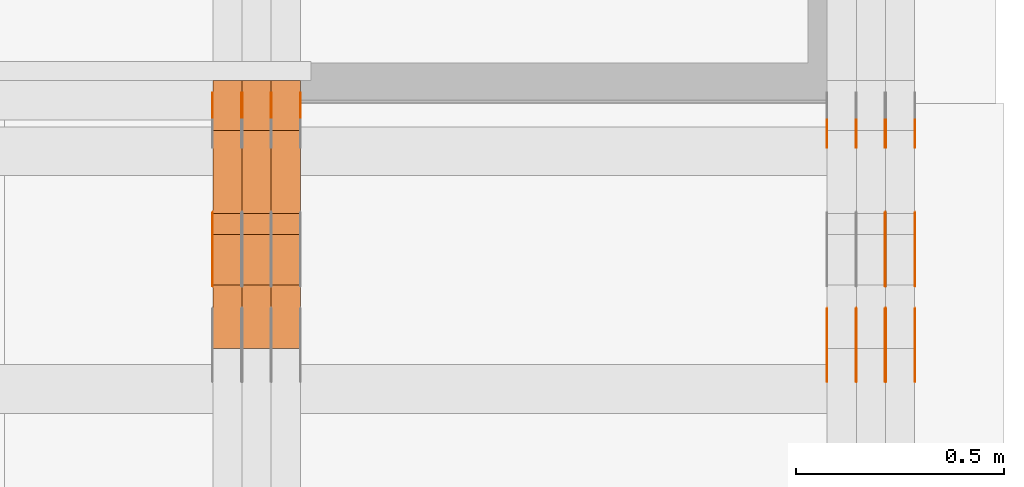
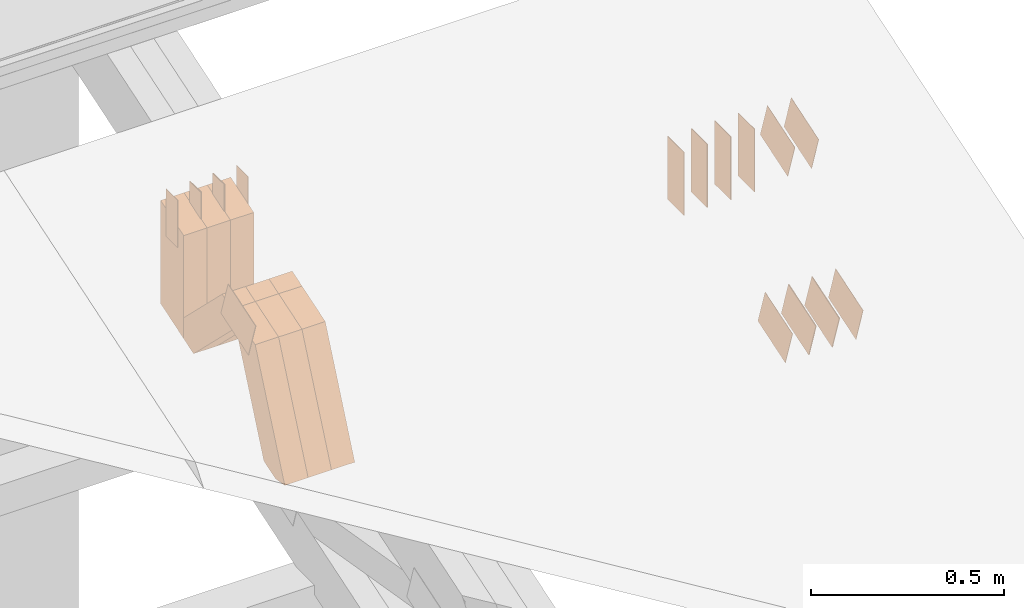
# One storey, part 323 of 385: 30 proxies.
"""IFC2X3 building model written with IfcOpenShell, lengths in millimetres."""

from ifc_helpers import new_model, entity, si_unit, converted_unit, derived_unit, direction, frame, frame_2d, origin, origin_2d_with_axis, place, context, subcontext, project, spatial, polyline, rectangle, outline, extrude, source, transform, mapped, material, type_object, type_shapes, element, save


model = new_model("IFC2X3")

# Units and contexts
model_context = context("Model", 3, precision=0.01, world=origin(), true_north=direction((6.12303176911189e-17, 1.0)))
body_context = subcontext(model_context, "Body", "Model", "MODEL_VIEW")
ifc_project = project(units=[si_unit("LENGTHUNIT", "METRE", prefix="MILLI"), si_unit("AREAUNIT", "SQUARE_METRE"), si_unit("VOLUMEUNIT", "CUBIC_METRE"), converted_unit("PLANEANGLEUNIT", "DEGREE", entity("IfcRatioMeasure", 0.0174532925199433), si_unit("PLANEANGLEUNIT", "RADIAN"), dimensions=[0, 0, 0, 0, 0, 0, 0]), si_unit("MASSUNIT", "GRAM", prefix="KILO"), derived_unit("MASSDENSITYUNIT", [(si_unit("MASSUNIT", "GRAM", prefix="KILO"), 1), (si_unit("LENGTHUNIT", "METRE"), -3)]), si_unit("TIMEUNIT", "SECOND"), si_unit("FREQUENCYUNIT", "HERTZ"), si_unit("THERMODYNAMICTEMPERATUREUNIT", "DEGREE_CELSIUS"), derived_unit("THERMALTRANSMITTANCEUNIT", [(si_unit("MASSUNIT", "GRAM", prefix="KILO"), 1), (si_unit("THERMODYNAMICTEMPERATUREUNIT", "KELVIN"), -1), (si_unit("TIMEUNIT", "SECOND"), -3)]), derived_unit("VOLUMETRICFLOWRATEUNIT", [(si_unit("LENGTHUNIT", "METRE"), 3), (si_unit("TIMEUNIT", "SECOND"), -1)]), si_unit("ELECTRICCURRENTUNIT", "AMPERE"), si_unit("ELECTRICVOLTAGEUNIT", "VOLT"), si_unit("POWERUNIT", "WATT"), si_unit("FORCEUNIT", "NEWTON", prefix="KILO"), si_unit("ILLUMINANCEUNIT", "LUX"), si_unit("LUMINOUSFLUXUNIT", "LUMEN"), si_unit("LUMINOUSINTENSITYUNIT", "CANDELA"), derived_unit("USERDEFINED", [(si_unit("MASSUNIT", "GRAM", prefix="KILO"), -1), (si_unit("LENGTHUNIT", "METRE"), -2), (si_unit("TIMEUNIT", "SECOND"), 3), (si_unit("LUMINOUSFLUXUNIT", "LUMEN"), 1)]), derived_unit("LINEARVELOCITYUNIT", [(si_unit("LENGTHUNIT", "METRE"), 1), (si_unit("TIMEUNIT", "SECOND"), -1)]), si_unit("PRESSUREUNIT", "PASCAL"), derived_unit("USERDEFINED", [(si_unit("LENGTHUNIT", "METRE"), -2), (si_unit("MASSUNIT", "GRAM", prefix="KILO"), 1), (si_unit("TIMEUNIT", "SECOND"), -2)])], contexts=[model_context])

# Site, building, storey
site_placement = place(None, origin())
site = spatial("IfcSite", under=ifc_project, at=site_placement, CompositionType="ELEMENT")
building_placement = place(site_placement, origin())
building = spatial("IfcBuilding", under=site, at=building_placement, CompositionType="ELEMENT")
storey_placement = place(building_placement, origin())
storey = spatial("IfcBuildingStorey", under=building, at=storey_placement, Name="Default", CompositionType="ELEMENT", Elevation=0.0)

# Proxies
ifc_material_1 = material(Name="IfcSurfaceStyle #622324")
building_element_proxy_type_1 = type_object("IfcBuildingElementProxyType", PredefinedType="NOTDEFINED", material=ifc_material_1)
shared_shape_1 = source(origin(), body_context, "Body", "SweptSolid", [
    extrude(rectangle(XDim=200.0, YDim=84.0, at=frame_2d((0.0, -7.105427357601e-15), x_axis=(1.0, 0.0))), frame((100.0, 42.0, 0.0), z_axis=(0.0, 0.0, 1.0), x_axis=(-1.0, 0.0, 0.0)), (0.0, 0.0, 1.0), 1.3),
])
type_shapes(building_element_proxy_type_1, [shared_shape_1])
proxy_1_placement = place(building_placement, frame((49861.3, 13702.0, 3651.4150390625), z_axis=(-1.0, 0.0, 0.0), x_axis=(0.0, 0.0, -1.0)))
element("IfcBuildingElementProxy", 1, at=proxy_1_placement, inside=storey, type_object=building_element_proxy_type_1, material=ifc_material_1, context=body_context, shape_type="MappedRepresentation", body=[
    mapped(shared_shape_1, transform((0.0, 0.0, 0.0), scale=1.0)),
])
ifc_material_2 = material(Name="IfcSurfaceStyle #622267")
building_element_proxy_type_2 = type_object("IfcBuildingElementProxyType", PredefinedType="NOTDEFINED", material=ifc_material_2)
shared_shape_2 = source(origin(), body_context, "Body", "SweptSolid", [
    extrude(rectangle(XDim=200.0, YDim=84.0, at=frame_2d((0.0, -7.105427357601e-15), x_axis=(1.0, 0.0))), frame((100.0, 42.0, 0.0), z_axis=(0.0, 0.0, 1.0), x_axis=(-1.0, 0.0, 0.0)), (0.0, 0.0, 1.0), 1.3),
])
type_shapes(building_element_proxy_type_2, [shared_shape_2])
proxy_2_placement = place(building_placement, frame((49790.0, 13702.0, 3651.4150390625), z_axis=(-1.0, 0.0, 0.0), x_axis=(0.0, 0.0, -1.0)))
element("IfcBuildingElementProxy", 2, at=proxy_2_placement, inside=storey, type_object=building_element_proxy_type_2, material=ifc_material_2, context=body_context, shape_type="MappedRepresentation", body=[
    mapped(shared_shape_2, transform((0.0, 0.0, 0.0), scale=1.0)),
])
ifc_material_3 = material(Name="IfcSurfaceStyle #622210")
building_element_proxy_type_3 = type_object("IfcBuildingElementProxyType", PredefinedType="NOTDEFINED", material=ifc_material_3)
shared_shape_3 = source(origin(), body_context, "Body", "SweptSolid", [
    extrude(rectangle(XDim=200.0, YDim=84.0, at=frame_2d((0.0, -7.105427357601e-15), x_axis=(1.0, 0.0))), frame((100.0, 42.0, 0.0), z_axis=(0.0, 0.0, 1.0), x_axis=(-1.0, 0.0, 0.0)), (0.0, 0.0, 1.0), 1.3),
])
type_shapes(building_element_proxy_type_3, [shared_shape_3])
proxy_3_placement = place(building_placement, frame((49791.3, 13702.0, 3651.4150390625), z_axis=(-1.0, 0.0, 0.0), x_axis=(0.0, 0.0, -1.0)))
element("IfcBuildingElementProxy", 3, at=proxy_3_placement, inside=storey, type_object=building_element_proxy_type_3, material=ifc_material_3, context=body_context, shape_type="MappedRepresentation", body=[
    mapped(shared_shape_3, transform((0.0, 0.0, 0.0), scale=1.0)),
])
ifc_material_4 = material(Name="IfcSurfaceStyle #622153")
building_element_proxy_type_4 = type_object("IfcBuildingElementProxyType", PredefinedType="NOTDEFINED", material=ifc_material_4)
shared_shape_4 = source(origin(), body_context, "Body", "SweptSolid", [
    extrude(rectangle(XDim=200.0, YDim=84.0, at=frame_2d((0.0, -7.105427357601e-15), x_axis=(1.0, 0.0))), frame((100.0, 42.0, 0.0), z_axis=(0.0, 0.0, 1.0), x_axis=(-1.0, 0.0, 0.0)), (0.0, 0.0, 1.0), 1.29999999999998),
])
type_shapes(building_element_proxy_type_4, [shared_shape_4])
proxy_4_placement = place(building_placement, frame((49720.0, 13702.0, 3651.4150390625), z_axis=(-1.0, 0.0, 0.0), x_axis=(0.0, 0.0, -1.0)))
element("IfcBuildingElementProxy", 4, at=proxy_4_placement, inside=storey, type_object=building_element_proxy_type_4, material=ifc_material_4, context=body_context, shape_type="MappedRepresentation", body=[
    mapped(shared_shape_4, transform((0.0, 0.0, 0.0), scale=1.0)),
])
ifc_material_5 = material(Name="IfcSurfaceStyle #622096")
building_element_proxy_type_5 = type_object("IfcBuildingElementProxyType", PredefinedType="NOTDEFINED", material=ifc_material_5)
shared_shape_5 = source(origin(), body_context, "Body", "SweptSolid", [
    extrude(rectangle(XDim=200.0, YDim=84.0, at=frame_2d((0.0, -7.105427357601e-15), x_axis=(1.0, 0.0))), frame((100.0, 42.0, 0.0), z_axis=(0.0, 0.0, 1.0), x_axis=(-1.0, 0.0, 0.0)), (0.0, 0.0, 1.0), 1.29999999999998),
])
type_shapes(building_element_proxy_type_5, [shared_shape_5])
proxy_5_placement = place(building_placement, frame((49721.3, 13702.0, 3651.4150390625), z_axis=(-1.0, 0.0, 0.0), x_axis=(0.0, 0.0, -1.0)))
element("IfcBuildingElementProxy", 5, at=proxy_5_placement, inside=storey, type_object=building_element_proxy_type_5, material=ifc_material_5, context=body_context, shape_type="MappedRepresentation", body=[
    mapped(shared_shape_5, transform((0.0, 0.0, 0.0), scale=1.0)),
])
ifc_material_6 = material(Name="IfcSurfaceStyle #622039")
building_element_proxy_type_6 = type_object("IfcBuildingElementProxyType", PredefinedType="NOTDEFINED", material=ifc_material_6)
shared_shape_6 = source(origin(), body_context, "Body", "SweptSolid", [
    extrude(rectangle(XDim=200.0, YDim=84.0, at=frame_2d((0.0, -7.105427357601e-15), x_axis=(1.0, 0.0))), frame((100.0, 42.0, 0.0), z_axis=(0.0, 0.0, 1.0), x_axis=(-1.0, 0.0, 0.0)), (0.0, 0.0, 1.0), 1.29999999999999),
])
type_shapes(building_element_proxy_type_6, [shared_shape_6])
proxy_6_placement = place(building_placement, frame((49650.0, 13702.0, 3651.4150390625), z_axis=(-1.0, 0.0, 0.0), x_axis=(0.0, 0.0, -1.0)))
element("IfcBuildingElementProxy", 6, at=proxy_6_placement, inside=storey, type_object=building_element_proxy_type_6, material=ifc_material_6, context=body_context, shape_type="MappedRepresentation", body=[
    mapped(shared_shape_6, transform((0.0, 0.0, 0.0), scale=1.0)),
])
ifc_material_7 = material(Name="IfcSurfaceStyle #621982")
building_element_proxy_type_7 = type_object("IfcBuildingElementProxyType", PredefinedType="NOTDEFINED", material=ifc_material_7)
shared_shape_7 = source(origin(), body_context, "Body", "SweptSolid", [
    extrude(outline(polyline([(-75.0003398116828, -59.9998507501386), (75.0003249421766, -59.9998507501386), (75.0003398116837, 59.9998507501387), (-75.0003249421775, 59.9998507501387), (-75.0003398116828, -59.9998507501386)])), frame((75.0003398116837, 60.0000773549637, 0.0), z_axis=(0.0, 0.0, 1.0), x_axis=(-1.0, 0.0, 0.0)), (0.0, 0.0, 1.0), 1.3),
])
type_shapes(building_element_proxy_type_7, [shared_shape_7])
proxy_7_placement = place(building_placement, frame((49861.3, 13054.73046875, 3417.8388671875), z_axis=(-1.0, 0.0, 0.0), x_axis=(0.0, 0.951056516295124, 0.309016994375039)))
element("IfcBuildingElementProxy", 7, at=proxy_7_placement, inside=storey, type_object=building_element_proxy_type_7, material=ifc_material_7, context=body_context, shape_type="MappedRepresentation", body=[
    mapped(shared_shape_7, transform((0.0, 0.0, 0.0), scale=1.0)),
])
ifc_material_8 = material(Name="IfcSurfaceStyle #621925")
building_element_proxy_type_8 = type_object("IfcBuildingElementProxyType", PredefinedType="NOTDEFINED", material=ifc_material_8)
shared_shape_8 = source(origin(), body_context, "Body", "SweptSolid", [
    extrude(outline(polyline([(-75.0003398116828, -59.9998507501386), (75.0003249421766, -59.9998507501386), (75.0003398116837, 59.9998507501387), (-75.0003249421775, 59.9998507501387), (-75.0003398116828, -59.9998507501386)])), frame((75.0003398116837, 60.0000773549637, 0.0), z_axis=(0.0, 0.0, 1.0), x_axis=(-1.0, 0.0, 0.0)), (0.0, 0.0, 1.0), 1.3),
])
type_shapes(building_element_proxy_type_8, [shared_shape_8])
proxy_8_placement = place(building_placement, frame((49790.0, 13054.73046875, 3417.8388671875), z_axis=(-1.0, 0.0, 0.0), x_axis=(0.0, 0.951056516295124, 0.309016994375039)))
element("IfcBuildingElementProxy", 8, at=proxy_8_placement, inside=storey, type_object=building_element_proxy_type_8, material=ifc_material_8, context=body_context, shape_type="MappedRepresentation", body=[
    mapped(shared_shape_8, transform((0.0, 0.0, 0.0), scale=1.0)),
])
ifc_material_9 = material(Name="IfcSurfaceStyle #621868")
building_element_proxy_type_9 = type_object("IfcBuildingElementProxyType", PredefinedType="NOTDEFINED", material=ifc_material_9)
shared_shape_9 = source(origin(), body_context, "Body", "SweptSolid", [
    extrude(outline(polyline([(-75.0003398116828, -59.9998507501386), (75.0003249421766, -59.9998507501386), (75.0003398116837, 59.9998507501387), (-75.0003249421775, 59.9998507501387), (-75.0003398116828, -59.9998507501386)])), frame((75.0003398116837, 60.0000773549637, 0.0), z_axis=(0.0, 0.0, 1.0), x_axis=(-1.0, 0.0, 0.0)), (0.0, 0.0, 1.0), 1.3),
])
type_shapes(building_element_proxy_type_9, [shared_shape_9])
proxy_9_placement = place(building_placement, frame((49791.3, 13054.73046875, 3417.8388671875), z_axis=(-1.0, 0.0, 0.0), x_axis=(0.0, 0.951056516295124, 0.309016994375039)))
element("IfcBuildingElementProxy", 9, at=proxy_9_placement, inside=storey, type_object=building_element_proxy_type_9, material=ifc_material_9, context=body_context, shape_type="MappedRepresentation", body=[
    mapped(shared_shape_9, transform((0.0, 0.0, 0.0), scale=1.0)),
])
ifc_material_10 = material(Name="IfcSurfaceStyle #621811")
building_element_proxy_type_10 = type_object("IfcBuildingElementProxyType", PredefinedType="NOTDEFINED", material=ifc_material_10)
shared_shape_10 = source(origin(), body_context, "Body", "SweptSolid", [
    extrude(outline(polyline([(-75.0003398116828, -59.9998507501386), (75.0003249421766, -59.9998507501386), (75.0003398116837, 59.9998507501387), (-75.0003249421775, 59.9998507501387), (-75.0003398116828, -59.9998507501386)])), frame((75.0003398116837, 60.0000773549637, 0.0), z_axis=(0.0, 0.0, 1.0), x_axis=(-1.0, 0.0, 0.0)), (0.0, 0.0, 1.0), 1.29999999999999),
])
type_shapes(building_element_proxy_type_10, [shared_shape_10])
proxy_10_placement = place(building_placement, frame((49720.0, 13054.73046875, 3417.8388671875), z_axis=(-1.0, 0.0, 0.0), x_axis=(0.0, 0.951056516295124, 0.309016994375039)))
element("IfcBuildingElementProxy", 10, at=proxy_10_placement, inside=storey, type_object=building_element_proxy_type_10, material=ifc_material_10, context=body_context, shape_type="MappedRepresentation", body=[
    mapped(shared_shape_10, transform((0.0, 0.0, 0.0), scale=1.0)),
])
ifc_material_11 = material(Name="IfcSurfaceStyle #621754")
building_element_proxy_type_11 = type_object("IfcBuildingElementProxyType", PredefinedType="NOTDEFINED", material=ifc_material_11)
shared_shape_11 = source(origin(), body_context, "Body", "SweptSolid", [
    extrude(outline(polyline([(-75.0003398116828, -59.9998507501386), (75.0003249421766, -59.9998507501386), (75.0003398116837, 59.9998507501387), (-75.0003249421775, 59.9998507501387), (-75.0003398116828, -59.9998507501386)])), frame((75.0003398116837, 60.0000773549637, 0.0), z_axis=(0.0, 0.0, 1.0), x_axis=(-1.0, 0.0, 0.0)), (0.0, 0.0, 1.0), 1.29999999999999),
])
type_shapes(building_element_proxy_type_11, [shared_shape_11])
proxy_11_placement = place(building_placement, frame((49721.3, 13054.73046875, 3417.8388671875), z_axis=(-1.0, 0.0, 0.0), x_axis=(0.0, 0.951056516295124, 0.309016994375039)))
element("IfcBuildingElementProxy", 11, at=proxy_11_placement, inside=storey, type_object=building_element_proxy_type_11, material=ifc_material_11, context=body_context, shape_type="MappedRepresentation", body=[
    mapped(shared_shape_11, transform((0.0, 0.0, 0.0), scale=1.0)),
])
ifc_material_12 = material(Name="IfcSurfaceStyle #621697")
building_element_proxy_type_12 = type_object("IfcBuildingElementProxyType", PredefinedType="NOTDEFINED", material=ifc_material_12)
shared_shape_12 = source(origin(), body_context, "Body", "SweptSolid", [
    extrude(outline(polyline([(-75.0003398116828, -59.9998507501386), (75.0003249421766, -59.9998507501386), (75.0003398116837, 59.9998507501387), (-75.0003249421775, 59.9998507501387), (-75.0003398116828, -59.9998507501386)])), frame((75.0003398116837, 60.0000773549637, 0.0), z_axis=(0.0, 0.0, 1.0), x_axis=(-1.0, 0.0, 0.0)), (0.0, 0.0, 1.0), 1.29999999999999),
])
type_shapes(building_element_proxy_type_12, [shared_shape_12])
proxy_12_placement = place(building_placement, frame((49650.0, 13054.73046875, 3417.8388671875), z_axis=(-1.0, 0.0, 0.0), x_axis=(0.0, 0.951056516295124, 0.309016994375039)))
element("IfcBuildingElementProxy", 12, at=proxy_12_placement, inside=storey, type_object=building_element_proxy_type_12, material=ifc_material_12, context=body_context, shape_type="MappedRepresentation", body=[
    mapped(shared_shape_12, transform((0.0, 0.0, 0.0), scale=1.0)),
])
ifc_material_13 = material(Name="IfcSurfaceStyle #614116")
building_element_proxy_type_13 = type_object("IfcBuildingElementProxyType", PredefinedType="NOTDEFINED", material=ifc_material_13)
shared_shape_13 = source(origin(), body_context, "Body", "SweptSolid", [
    extrude(outline(polyline([(-74.999875428623, -60.0000016373506), (74.9998605591059, -60.0000016373506), (74.9998754286239, 60.0000016373506), (-74.9998605591068, 60.0000016373506), (-74.999875428623, -60.0000016373506)])), frame((75.0002691827262, 60.0000190504561, 0.0), z_axis=(0.0, 0.0, 1.0), x_axis=(-1.0, 0.0, 0.0)), (0.0, 0.0, 1.0), 1.3),
])
type_shapes(building_element_proxy_type_13, [shared_shape_13])
proxy_13_placement = place(building_placement, frame((49861.3, 13285.0865109705, 3819.37496637467), z_axis=(-1.0, 0.0, 0.0), x_axis=(0.0, 0.951056516295154, 0.309016994374948)))
element("IfcBuildingElementProxy", 13, at=proxy_13_placement, inside=storey, type_object=building_element_proxy_type_13, material=ifc_material_13, context=body_context, shape_type="MappedRepresentation", body=[
    mapped(shared_shape_13, transform((0.0, 0.0, 0.0), scale=1.0)),
])
ifc_material_14 = material(Name="IfcSurfaceStyle #614059")
building_element_proxy_type_14 = type_object("IfcBuildingElementProxyType", PredefinedType="NOTDEFINED", material=ifc_material_14)
shared_shape_14 = source(origin(), body_context, "Body", "SweptSolid", [
    extrude(outline(polyline([(-74.999875428623, -60.0000016373506), (74.9998605591059, -60.0000016373506), (74.9998754286239, 60.0000016373506), (-74.9998605591068, 60.0000016373506), (-74.999875428623, -60.0000016373506)])), frame((75.0002691827262, 60.0000190504561, 0.0), z_axis=(0.0, 0.0, 1.0), x_axis=(-1.0, 0.0, 0.0)), (0.0, 0.0, 1.0), 1.3),
])
type_shapes(building_element_proxy_type_14, [shared_shape_14])
proxy_14_placement = place(building_placement, frame((49790.0, 13285.0865109705, 3819.37496637467), z_axis=(-1.0, 0.0, 0.0), x_axis=(0.0, 0.951056516295154, 0.309016994374948)))
element("IfcBuildingElementProxy", 14, at=proxy_14_placement, inside=storey, type_object=building_element_proxy_type_14, material=ifc_material_14, context=body_context, shape_type="MappedRepresentation", body=[
    mapped(shared_shape_14, transform((0.0, 0.0, 0.0), scale=1.0)),
])
ifc_material_15 = material(Name="IfcSurfaceStyle #579399")
building_element_proxy_type_15 = type_object("IfcBuildingElementProxyType", PredefinedType="NOTDEFINED", material=ifc_material_15)
shared_shape_15 = source(origin(), body_context, "Body", "SweptSolid", [
    extrude(outline(polyline([(-74.999875428623, -60.0000016373506), (74.9998605591059, -60.0000016373506), (74.9998754286239, 60.0000016373506), (-74.9998605591068, 60.0000016373506), (-74.999875428623, -60.0000016373506)])), frame((75.0002691827262, 60.0000190504561, 0.0), z_axis=(0.0, 0.0, 1.0), x_axis=(-1.0, 0.0, 0.0)), (0.0, 0.0, 1.0), 1.29999999999999),
])
type_shapes(building_element_proxy_type_15, [shared_shape_15])
proxy_15_placement = place(building_placement, frame((48175.0, 13285.0865109705, 3819.37496637467), z_axis=(-1.0, 0.0, 0.0), x_axis=(0.0, 0.951056516295154, 0.309016994374948)))
element("IfcBuildingElementProxy", 15, at=proxy_15_placement, inside=storey, type_object=building_element_proxy_type_15, material=ifc_material_15, context=body_context, shape_type="MappedRepresentation", body=[
    mapped(shared_shape_15, transform((0.0, 0.0, 0.0), scale=1.0)),
])
ifc_material_16 = material(Name="IfcSurfaceStyle #579000")
building_element_proxy_type_16 = type_object("IfcBuildingElementProxyType", PredefinedType="NOTDEFINED", material=ifc_material_16)
shared_shape_16 = source(origin(), body_context, "Body", "SweptSolid", [
    extrude(rectangle(XDim=150.0, YDim=60.0, at=origin_2d_with_axis()), frame((75.0000705696166, 30.0, 0.0), z_axis=(0.0, 0.0, 1.0), x_axis=(-1.0, 0.0, 0.0)), (0.0, 0.0, 1.0), 1.3),
])
type_shapes(building_element_proxy_type_16, [shared_shape_16])
proxy_16_placement = place(building_placement, frame((48386.3, 13750.0, 3972.59919166337), z_axis=(-1.0, 0.0, 0.0), x_axis=(0.0, 0.0, -1.0)))
element("IfcBuildingElementProxy", 16, at=proxy_16_placement, inside=storey, type_object=building_element_proxy_type_16, material=ifc_material_16, context=body_context, shape_type="MappedRepresentation", body=[
    mapped(shared_shape_16, transform((0.0, 0.0, 0.0), scale=1.0)),
])
ifc_material_17 = material(Name="IfcSurfaceStyle #578943")
building_element_proxy_type_17 = type_object("IfcBuildingElementProxyType", PredefinedType="NOTDEFINED", material=ifc_material_17)
shared_shape_17 = source(origin(), body_context, "Body", "SweptSolid", [
    extrude(rectangle(XDim=150.0, YDim=60.0, at=origin_2d_with_axis()), frame((75.0000705696166, 30.0, 0.0), z_axis=(0.0, 0.0, 1.0), x_axis=(-1.0, 0.0, 0.0)), (0.0, 0.0, 1.0), 1.3),
])
type_shapes(building_element_proxy_type_17, [shared_shape_17])
proxy_17_placement = place(building_placement, frame((48315.0, 13750.0, 3972.59919166337), z_axis=(-1.0, 0.0, 0.0), x_axis=(0.0, 0.0, -1.0)))
element("IfcBuildingElementProxy", 17, at=proxy_17_placement, inside=storey, type_object=building_element_proxy_type_17, material=ifc_material_17, context=body_context, shape_type="MappedRepresentation", body=[
    mapped(shared_shape_17, transform((0.0, 0.0, 0.0), scale=1.0)),
])
ifc_material_18 = material(Name="IfcSurfaceStyle #578886")
building_element_proxy_type_18 = type_object("IfcBuildingElementProxyType", PredefinedType="NOTDEFINED", material=ifc_material_18)
shared_shape_18 = source(origin(), body_context, "Body", "SweptSolid", [
    extrude(rectangle(XDim=150.0, YDim=60.0, at=origin_2d_with_axis()), frame((75.0000705696166, 30.0, 0.0), z_axis=(0.0, 0.0, 1.0), x_axis=(-1.0, 0.0, 0.0)), (0.0, 0.0, 1.0), 1.3),
])
type_shapes(building_element_proxy_type_18, [shared_shape_18])
proxy_18_placement = place(building_placement, frame((48316.3, 13750.0, 3972.59919166337), z_axis=(-1.0, 0.0, 0.0), x_axis=(0.0, 0.0, -1.0)))
element("IfcBuildingElementProxy", 18, at=proxy_18_placement, inside=storey, type_object=building_element_proxy_type_18, material=ifc_material_18, context=body_context, shape_type="MappedRepresentation", body=[
    mapped(shared_shape_18, transform((0.0, 0.0, 0.0), scale=1.0)),
])
ifc_material_19 = material(Name="IfcSurfaceStyle #578829")
building_element_proxy_type_19 = type_object("IfcBuildingElementProxyType", PredefinedType="NOTDEFINED", material=ifc_material_19)
shared_shape_19 = source(origin(), body_context, "Body", "SweptSolid", [
    extrude(rectangle(XDim=150.0, YDim=60.0, at=origin_2d_with_axis()), frame((75.0000705696166, 30.0, 0.0), z_axis=(0.0, 0.0, 1.0), x_axis=(-1.0, 0.0, 0.0)), (0.0, 0.0, 1.0), 1.29999999999999),
])
type_shapes(building_element_proxy_type_19, [shared_shape_19])
proxy_19_placement = place(building_placement, frame((48245.0, 13750.0, 3972.59919166337), z_axis=(-1.0, 0.0, 0.0), x_axis=(0.0, 0.0, -1.0)))
element("IfcBuildingElementProxy", 19, at=proxy_19_placement, inside=storey, type_object=building_element_proxy_type_19, material=ifc_material_19, context=body_context, shape_type="MappedRepresentation", body=[
    mapped(shared_shape_19, transform((0.0, 0.0, 0.0), scale=1.0)),
])
ifc_material_20 = material(Name="IfcSurfaceStyle #578772")
building_element_proxy_type_20 = type_object("IfcBuildingElementProxyType", PredefinedType="NOTDEFINED", material=ifc_material_20)
shared_shape_20 = source(origin(), body_context, "Body", "SweptSolid", [
    extrude(rectangle(XDim=150.0, YDim=60.0, at=origin_2d_with_axis()), frame((75.0000705696166, 30.0, 0.0), z_axis=(0.0, 0.0, 1.0), x_axis=(-1.0, 0.0, 0.0)), (0.0, 0.0, 1.0), 1.29999999999999),
])
type_shapes(building_element_proxy_type_20, [shared_shape_20])
proxy_20_placement = place(building_placement, frame((48246.3, 13750.0, 3972.59919166337), z_axis=(-1.0, 0.0, 0.0), x_axis=(0.0, 0.0, -1.0)))
element("IfcBuildingElementProxy", 20, at=proxy_20_placement, inside=storey, type_object=building_element_proxy_type_20, material=ifc_material_20, context=body_context, shape_type="MappedRepresentation", body=[
    mapped(shared_shape_20, transform((0.0, 0.0, 0.0), scale=1.0)),
])
ifc_material_21 = material(Name="IfcSurfaceStyle #578715")
building_element_proxy_type_21 = type_object("IfcBuildingElementProxyType", PredefinedType="NOTDEFINED", material=ifc_material_21)
shared_shape_21 = source(origin(), body_context, "Body", "SweptSolid", [
    extrude(rectangle(XDim=150.0, YDim=60.0, at=origin_2d_with_axis()), frame((75.0000705696166, 30.0, 0.0), z_axis=(0.0, 0.0, 1.0), x_axis=(-1.0, 0.0, 0.0)), (0.0, 0.0, 1.0), 1.29999999999999),
])
type_shapes(building_element_proxy_type_21, [shared_shape_21])
proxy_21_placement = place(building_placement, frame((48175.0, 13750.0, 3972.59919166337), z_axis=(-1.0, 0.0, 0.0), x_axis=(0.0, 0.0, -1.0)))
element("IfcBuildingElementProxy", 21, at=proxy_21_placement, inside=storey, type_object=building_element_proxy_type_21, material=ifc_material_21, context=body_context, shape_type="MappedRepresentation", body=[
    mapped(shared_shape_21, transform((0.0, 0.0, 0.0), scale=1.0)),
])
ifc_material_22 = material(Name="IfcSurfaceStyle #569514")
building_element_proxy_type_22 = type_object("IfcBuildingElementProxyType", Name="T1-W49 569512", PredefinedType="NOTDEFINED", material=ifc_material_22)
shared_shape_22 = source(origin(), body_context, "Body", "SweptSolid", [
    extrude(outline(polyline([(-155.175867306415, -47.4997478409253), (152.310664695054, -47.4997478409253), (170.496756790954, -6.14570120142345e-05), (145.70957993751, 47.4998092979374), (-133.37808995724, 47.4998092979373), (-179.963044159863, -6.14570120298391e-05), (-155.175867306415, -47.4997478409253)])), frame((170.496756790954, 47.5001152140455, 0.0), z_axis=(0.0, 0.0, 1.0), x_axis=(-1.0, 0.0, 0.0)), (0.0, 0.0, 1.0), 70.0),
])
type_shapes(building_element_proxy_type_22, [shared_shape_22])
proxy_22_placement = place(building_placement, frame((48385.0, 13443.048524104, 3830.71841973934), z_axis=(-1.0, 0.0, 0.0), x_axis=(0.0, 0.713950095632063, -0.700196587357413)))
element("IfcBuildingElementProxy", 22, at=proxy_22_placement, inside=storey, type_object=building_element_proxy_type_22, material=ifc_material_22, Name="T1-W49", context=body_context, shape_type="MappedRepresentation", body=[
    mapped(shared_shape_22, transform((0.0, 0.0, 0.0), scale=1.0)),
])
ifc_material_23 = material(Name="IfcSurfaceStyle #569439")
building_element_proxy_type_23 = type_object("IfcBuildingElementProxyType", Name="T1-W49 569437", PredefinedType="NOTDEFINED", material=ifc_material_23)
shared_shape_23 = source(origin(), body_context, "Body", "SweptSolid", [
    extrude(outline(polyline([(-155.175867306415, -47.4997478409253), (152.310664695054, -47.4997478409253), (170.496756790954, -6.14570120142345e-05), (145.70957993751, 47.4998092979374), (-133.37808995724, 47.4998092979373), (-179.963044159863, -6.14570120298391e-05), (-155.175867306415, -47.4997478409253)])), frame((170.496756790954, 47.5001152140455, 0.0), z_axis=(0.0, 0.0, 1.0), x_axis=(-1.0, 0.0, 0.0)), (0.0, 0.0, 1.0), 70.0),
])
type_shapes(building_element_proxy_type_23, [shared_shape_23])
proxy_23_placement = place(building_placement, frame((48315.0, 13443.048524104, 3830.71841973934), z_axis=(-1.0, 0.0, 0.0), x_axis=(0.0, 0.713950095632063, -0.700196587357413)))
element("IfcBuildingElementProxy", 23, at=proxy_23_placement, inside=storey, type_object=building_element_proxy_type_23, material=ifc_material_23, Name="T1-W49", context=body_context, shape_type="MappedRepresentation", body=[
    mapped(shared_shape_23, transform((0.0, 0.0, 0.0), scale=1.0)),
])
ifc_material_24 = material(Name="IfcSurfaceStyle #569364")
building_element_proxy_type_24 = type_object("IfcBuildingElementProxyType", Name="T1-W49 569362", PredefinedType="NOTDEFINED", material=ifc_material_24)
shared_shape_24 = source(origin(), body_context, "Body", "SweptSolid", [
    extrude(outline(polyline([(-155.175867306415, -47.4997478409253), (152.310664695054, -47.4997478409253), (170.496756790954, -6.14570120142345e-05), (145.70957993751, 47.4998092979374), (-133.37808995724, 47.4998092979373), (-179.963044159863, -6.14570120298391e-05), (-155.175867306415, -47.4997478409253)])), frame((170.496756790954, 47.5001152140455, 0.0), z_axis=(0.0, 0.0, 1.0), x_axis=(-1.0, 0.0, 0.0)), (0.0, 0.0, 1.0), 70.0),
])
type_shapes(building_element_proxy_type_24, [shared_shape_24])
proxy_24_placement = place(building_placement, frame((48245.0, 13443.048524104, 3830.71841973934), z_axis=(-1.0, 0.0, 0.0), x_axis=(0.0, 0.713950095632063, -0.700196587357413)))
element("IfcBuildingElementProxy", 24, at=proxy_24_placement, inside=storey, type_object=building_element_proxy_type_24, material=ifc_material_24, Name="T1-W49", context=body_context, shape_type="MappedRepresentation", body=[
    mapped(shared_shape_24, transform((0.0, 0.0, 0.0), scale=1.0)),
])
ifc_material_25 = material(Name="IfcSurfaceStyle #569064")
building_element_proxy_type_25 = type_object("IfcBuildingElementProxyType", Name="T1-W1 569062", PredefinedType="NOTDEFINED", material=ifc_material_25)
shared_shape_25 = source(origin(), body_context, "Body", "SweptSolid", [
    extrude(outline(polyline([(-182.839782714844, -60.0), (143.849426269531, -60.0), (182.839660644531, 60.0), (-143.849304199219, 60.0), (-182.839782714844, -60.0)])), frame((182.839674685549, 60.0, 0.0), z_axis=(0.0, 0.0, 1.0), x_axis=(-1.0, 0.0, 0.0)), (0.0, 0.0, 1.0), 70.0),
])
type_shapes(building_element_proxy_type_25, [shared_shape_25])
proxy_25_placement = place(building_placement, frame((48385.0, 13660.0, 3551.41502502148), z_axis=(-1.0, 0.0, 0.0), x_axis=(0.0, 0.0, 1.0)))
element("IfcBuildingElementProxy", 25, at=proxy_25_placement, inside=storey, type_object=building_element_proxy_type_25, material=ifc_material_25, Name="T1-W1", context=body_context, shape_type="MappedRepresentation", body=[
    mapped(shared_shape_25, transform((0.0, 0.0, 0.0), scale=1.0)),
])
ifc_material_26 = material(Name="IfcSurfaceStyle #569007")
building_element_proxy_type_26 = type_object("IfcBuildingElementProxyType", Name="T1-W1 569005", PredefinedType="NOTDEFINED", material=ifc_material_26)
shared_shape_26 = source(origin(), body_context, "Body", "SweptSolid", [
    extrude(outline(polyline([(-182.839782714844, -60.0), (143.849426269531, -60.0), (182.839660644531, 60.0), (-143.849304199219, 60.0), (-182.839782714844, -60.0)])), frame((182.839674685549, 60.0, 0.0), z_axis=(0.0, 0.0, 1.0), x_axis=(-1.0, 0.0, 0.0)), (0.0, 0.0, 1.0), 70.0),
])
type_shapes(building_element_proxy_type_26, [shared_shape_26])
proxy_26_placement = place(building_placement, frame((48315.0, 13660.0, 3551.41502502148), z_axis=(-1.0, 0.0, 0.0), x_axis=(0.0, 0.0, 1.0)))
element("IfcBuildingElementProxy", 26, at=proxy_26_placement, inside=storey, type_object=building_element_proxy_type_26, material=ifc_material_26, Name="T1-W1", context=body_context, shape_type="MappedRepresentation", body=[
    mapped(shared_shape_26, transform((0.0, 0.0, 0.0), scale=1.0)),
])
ifc_material_27 = material(Name="IfcSurfaceStyle #568950")
building_element_proxy_type_27 = type_object("IfcBuildingElementProxyType", Name="T1-W1 568948", PredefinedType="NOTDEFINED", material=ifc_material_27)
shared_shape_27 = source(origin(), body_context, "Body", "SweptSolid", [
    extrude(outline(polyline([(-182.839782714844, -60.0), (143.849426269531, -60.0), (182.839660644531, 60.0), (-143.849304199219, 60.0), (-182.839782714844, -60.0)])), frame((182.839674685549, 60.0, 0.0), z_axis=(0.0, 0.0, 1.0), x_axis=(-1.0, 0.0, 0.0)), (0.0, 0.0, 1.0), 70.0),
])
type_shapes(building_element_proxy_type_27, [shared_shape_27])
proxy_27_placement = place(building_placement, frame((48245.0, 13660.0, 3551.41502502148), z_axis=(-1.0, 0.0, 0.0), x_axis=(0.0, 0.0, 1.0)))
element("IfcBuildingElementProxy", 27, at=proxy_27_placement, inside=storey, type_object=building_element_proxy_type_27, material=ifc_material_27, Name="T1-W1", context=body_context, shape_type="MappedRepresentation", body=[
    mapped(shared_shape_27, transform((0.0, 0.0, 0.0), scale=1.0)),
])
ifc_material_28 = material(Name="IfcSurfaceStyle #568524")
building_element_proxy_type_28 = type_object("IfcBuildingElementProxyType", Name="T1-W42 568522", PredefinedType="NOTDEFINED", material=ifc_material_28)
shared_shape_28 = source(origin(), body_context, "Body", "SweptSolid", [
    extrude(outline(polyline([(-284.837590197601, -47.4997543607933), (129.95880168156, -47.4997543607933), (171.972324990451, 0.000162623346093338), (183.717007105413, 47.4996730491203), (-200.810543579822, 47.4996730491203), (-284.837590197601, -47.4997543607933)])), frame((183.717155718752, 47.4999821655365, 0.0), z_axis=(0.0, 0.0, 1.0), x_axis=(-1.0, 0.0, 0.0)), (0.0, 0.0, 1.0), 70.0),
])
type_shapes(building_element_proxy_type_28, [shared_shape_28])
proxy_28_placement = place(building_placement, frame((48385.0, 13135.8834463264, 3404.958483022), z_axis=(-1.0, 0.0, 0.0), x_axis=(0.0, 0.398630596470292, 0.917111578575769)))
element("IfcBuildingElementProxy", 28, at=proxy_28_placement, inside=storey, type_object=building_element_proxy_type_28, material=ifc_material_28, Name="T1-W42", context=body_context, shape_type="MappedRepresentation", body=[
    mapped(shared_shape_28, transform((0.0, 0.0, 0.0), scale=1.0)),
])
ifc_material_29 = material(Name="IfcSurfaceStyle #568458")
building_element_proxy_type_29 = type_object("IfcBuildingElementProxyType", Name="T1-W42 568456", PredefinedType="NOTDEFINED", material=ifc_material_29)
shared_shape_29 = source(origin(), body_context, "Body", "SweptSolid", [
    extrude(outline(polyline([(-284.837590197601, -47.4997543607933), (129.95880168156, -47.4997543607933), (171.972324990451, 0.000162623346093338), (183.717007105413, 47.4996730491203), (-200.810543579822, 47.4996730491203), (-284.837590197601, -47.4997543607933)])), frame((183.717155718752, 47.4999821655365, 0.0), z_axis=(0.0, 0.0, 1.0), x_axis=(-1.0, 0.0, 0.0)), (0.0, 0.0, 1.0), 70.0),
])
type_shapes(building_element_proxy_type_29, [shared_shape_29])
proxy_29_placement = place(building_placement, frame((48315.0, 13135.8834463264, 3404.958483022), z_axis=(-1.0, 0.0, 0.0), x_axis=(0.0, 0.398630596470292, 0.917111578575769)))
element("IfcBuildingElementProxy", 29, at=proxy_29_placement, inside=storey, type_object=building_element_proxy_type_29, material=ifc_material_29, Name="T1-W42", context=body_context, shape_type="MappedRepresentation", body=[
    mapped(shared_shape_29, transform((0.0, 0.0, 0.0), scale=1.0)),
])
ifc_material_30 = material(Name="IfcSurfaceStyle #568392")
building_element_proxy_type_30 = type_object("IfcBuildingElementProxyType", Name="T1-W42 568390", PredefinedType="NOTDEFINED", material=ifc_material_30)
shared_shape_30 = source(origin(), body_context, "Body", "SweptSolid", [
    extrude(outline(polyline([(-284.837590197601, -47.4997543607933), (129.95880168156, -47.4997543607933), (171.972324990451, 0.000162623346093338), (183.717007105413, 47.4996730491203), (-200.810543579822, 47.4996730491203), (-284.837590197601, -47.4997543607933)])), frame((183.717155718752, 47.4999821655365, 0.0), z_axis=(0.0, 0.0, 1.0), x_axis=(-1.0, 0.0, 0.0)), (0.0, 0.0, 1.0), 70.0),
])
type_shapes(building_element_proxy_type_30, [shared_shape_30])
proxy_30_placement = place(building_placement, frame((48245.0, 13135.8834463264, 3404.958483022), z_axis=(-1.0, 0.0, 0.0), x_axis=(0.0, 0.398630596470292, 0.917111578575769)))
element("IfcBuildingElementProxy", 30, at=proxy_30_placement, inside=storey, type_object=building_element_proxy_type_30, material=ifc_material_30, Name="T1-W42", context=body_context, shape_type="MappedRepresentation", body=[
    mapped(shared_shape_30, transform((0.0, 0.0, 0.0), scale=1.0)),
])

save(model, "model.ifc")
